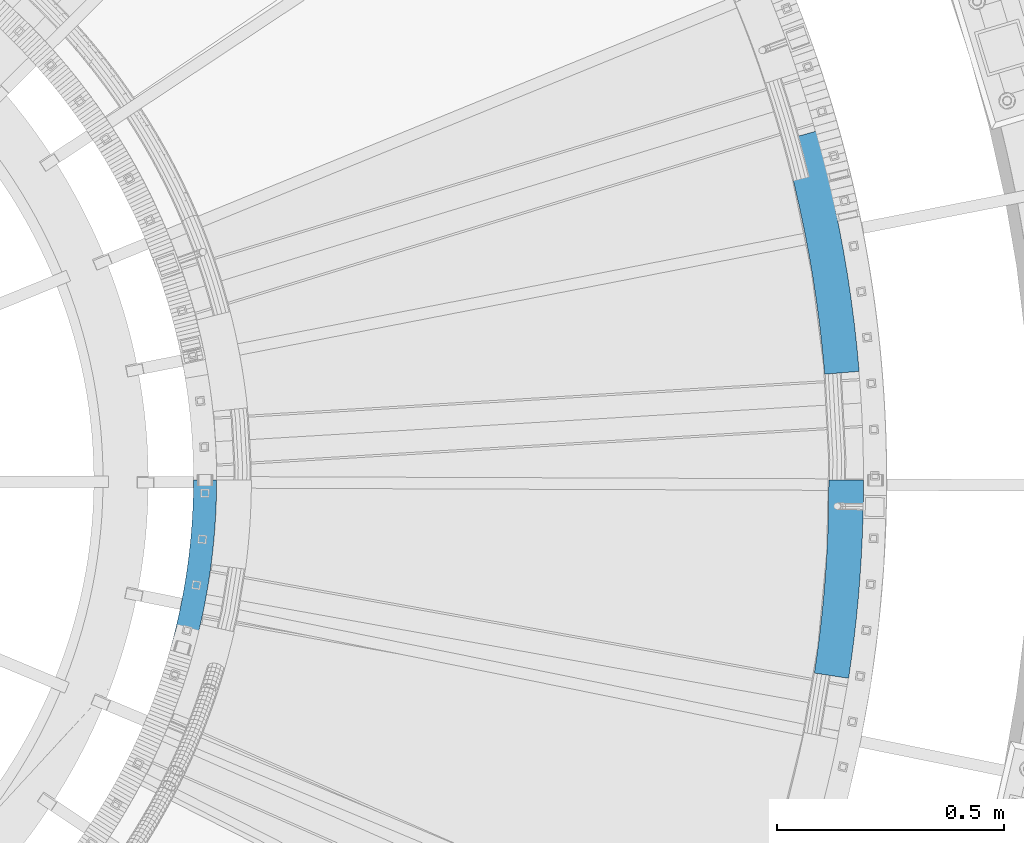
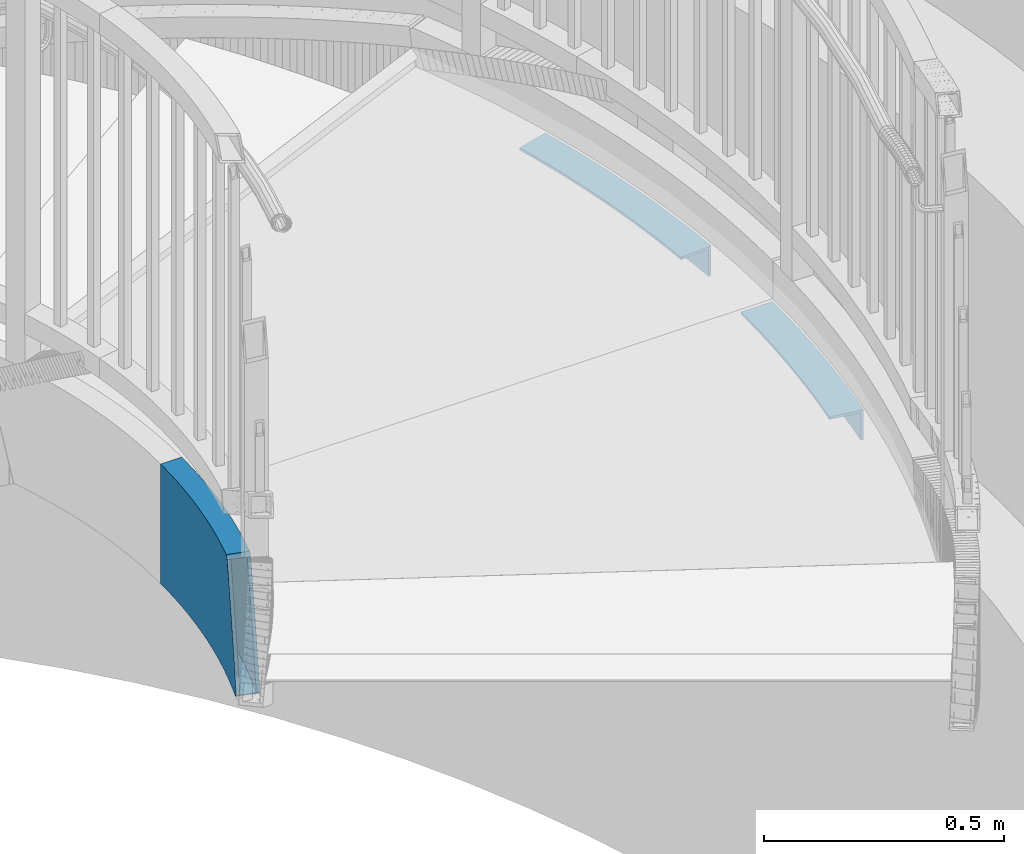
# One storey, part 503 of 975: 3 beams.
"""IFC2X3 building model written with IfcOpenShell, lengths in millimetres."""

from ifc_helpers import new_model, si_unit, frame, origin_with_axes, place, context, subcontext, project, spatial, faceted_brep, material, type_object, element, save


model = new_model("IFC2X3")

# Units and contexts
model_context = context("Model", 3, precision=1e-05, world=origin_with_axes())
body_context = subcontext(model_context, "Body", "Model", "MODEL_VIEW")
ifc_project = project(units=[si_unit("LENGTHUNIT", "METRE", prefix="MILLI"), si_unit("AREAUNIT", "SQUARE_METRE"), si_unit("VOLUMEUNIT", "CUBIC_METRE"), si_unit("MASSUNIT", "GRAM", prefix="KILO"), si_unit("TIMEUNIT", "SECOND"), si_unit("PLANEANGLEUNIT", "RADIAN"), si_unit("SOLIDANGLEUNIT", "STERADIAN"), si_unit("THERMODYNAMICTEMPERATUREUNIT", "DEGREE_CELSIUS"), si_unit("LUMINOUSINTENSITYUNIT", "LUMEN")], contexts=[model_context])

# Site, building, storey
site_placement = place(None, origin_with_axes())
site = spatial("IfcSite", under=ifc_project, at=site_placement, CompositionType="ELEMENT")
building_placement = place(site_placement, origin_with_axes())
building = spatial("IfcBuilding", under=site, at=building_placement, Name="Undefined", CompositionType="ELEMENT")
storey_placement = place(building_placement, origin_with_axes())
storey = spatial("IfcBuildingStorey", under=building, at=storey_placement, Name="Undefined", CompositionType="ELEMENT", Elevation=0.0)

# Beams
ifc_material_1 = material(Name="STEEL/A36")
beam_type_1 = type_object("IfcBeamType", Name="L3X3X1/4", PredefinedType="NOTDEFINED")
beam_1_placement = place(storey_placement, frame((37541.2001337016, 3403.49906415953, 2044.7), z_axis=(-0.997215696364152, 0.0745711400272229, 0.0), x_axis=(-0.0745711400272231, -0.997215696364152, 0.0)))
element("IfcBeam", 1, at=beam_1_placement, inside=storey, type_object=beam_type_1, material=ifc_material_1, Name="ANGLE", ObjectType="L3X3X1/4", context=body_context, shape_type="Brep", body=[
    faceted_brep([(2.94180525661432, 38.0999999999999, 37.9862578023894), (2.94180525661432, 31.75, 37.9862578023894), (45.4166700735695, 31.75, 35.0269018917315), (45.4166700735695, 38.0999999999999, 35.0269018917315), (-2.45150438051314, 31.75, -31.6552148353221), (-2.45150438051314, -38.0999999999999, -31.6552148353221), (41.1004751186192, -38.0999999999999, -34.6896166752631), (41.1004751186192, 31.75, -34.6896166752631), (-2.94180525661523, -38.0999999999999, -37.9862578023894), (-2.94180525661523, 38.0999999999999, -37.9862578023894), (40.7080937590763, 38.0999999999999, -41.027481999532), (40.7080937590763, -38.0999999999999, -41.027481999532), (87.9322040593433, 31.75, 32.7244469998332), (87.9322040593433, 38.0999999999999, 32.7244469998332), (84.6941551108348, -38.0999999999999, -37.0504592272482), (84.6941551108348, 31.75, -37.0504592272482), (84.3997870246076, 38.0999999999999, -43.3936325206159), (84.3997870246076, -38.0999999999999, -43.3936325206159), (130.47824842769, 31.75, 31.0794432820112), (130.47824842769, 38.0999999999999, 31.0794432820112), (128.319119194526, -38.0999999999999, -38.7371783846538), (128.319119194526, 31.75, -38.7371783846538), (128.122834718784, 38.0999999999999, -45.084143990709), (128.122834718784, -38.0999999999999, -45.084143990709), (173.044637102121, 31.75, 30.0922838002589), (173.044637102121, 38.0999999999999, 30.0922838002589), (171.964943492967, -38.0999999999999, -39.749371117854), (171.964943492967, 31.75, -39.749371117854), (171.866789528498, 38.0999999999999, -46.0986124740448), (171.866789528498, -38.0999999999999, -46.0986124740448), (215.621199145022, 31.75, 29.7632044293787), (215.621199145022, 38.0999999999999, 29.7632044293787), (215.621199145031, -38.0999999999999, -40.0867955705544), (215.621199145031, 31.75, -40.0867955705544), (215.621199145031, 38.0999999999999, -46.4367955705457), (215.621199145031, -38.0999999999999, -46.4367955705457), (258.197761187923, 31.75, 30.0922838005426), (258.197761187923, 38.0999999999999, 30.0922838005426), (259.277454797095, -38.0999999999999, -39.749371117563), (259.277454797095, 31.75, -39.749371117563), (259.375608761566, 38.0999999999999, -46.098612473761), (259.375608761566, -38.0999999999999, -46.098612473761), (300.764149862352, 31.75, 31.0794432825569), (300.764149862352, 38.0999999999999, 31.0794432825569), (302.923279095534, -38.0999999999999, -38.7371783840863), (302.923279095534, 31.75, -38.7371783840863), (303.119563571277, 38.0999999999999, -45.0841439901415), (303.119563571277, -38.0999999999999, -45.0841439901415), (343.310194230698, 31.75, 32.7244470006699), (343.310194230698, 38.0999999999999, 32.7244470006699), (346.548243179226, -38.0999999999999, -37.0504592264042), (346.548243179226, 31.75, -37.0504592264042), (346.842611265455, 38.0999999999999, -43.3936325197719), (346.842611265455, -38.0999999999999, -43.3936325197719), (385.825728216472, 31.75, 35.0269018928302), (385.825728216472, 38.0999999999999, 35.0269018928302), (390.141923171442, -38.0999999999999, -34.6896166741353), (390.141923171442, 31.75, -34.6896166741353), (390.534304530984, 38.0999999999999, -41.0274819984043), (390.534304530984, -38.0999999999999, -41.0274819984043), (428.300593033427, 38.0999999999999, 37.9862578037646), (434.184203546676, 38.0999999999999, -37.9862578009852), (428.300593033427, 31.75, 37.9862578037646), (433.693902670571, 31.75, -31.6552148339179), (433.693902670571, -38.0999999999999, -31.6552148339179), (434.184203546676, -38.0999999999999, -37.9862578009852)], [[[0, 1, 2, 3]], [[4, 5, 6, 7]], [[8, 9, 10, 11]], [[8, 5, 4, 1, 0, 9]], [[3, 2, 12, 13]], [[7, 6, 14, 15]], [[11, 10, 16, 17]], [[13, 12, 18, 19]], [[15, 14, 20, 21]], [[17, 16, 22, 23]], [[19, 18, 24, 25]], [[21, 20, 26, 27]], [[23, 22, 28, 29]], [[25, 24, 30, 31]], [[27, 26, 32, 33]], [[29, 28, 34, 35]], [[31, 30, 36, 37]], [[33, 32, 38, 39]], [[35, 34, 40, 41]], [[37, 36, 42, 43]], [[39, 38, 44, 45]], [[41, 40, 46, 47]], [[43, 42, 48, 49]], [[45, 44, 50, 51]], [[47, 46, 52, 53]], [[49, 48, 54, 55]], [[51, 50, 56, 57]], [[53, 52, 58, 59]], [[58, 52, 46, 40, 34, 28, 22, 16, 10, 9, 0, 3, 13, 19, 25, 31, 37, 43, 49, 55, 60, 61]], [[55, 54, 62, 60]], [[54, 48, 42, 36, 30, 24, 18, 12, 2, 1, 4, 7, 15, 21, 27, 33, 39, 45, 51, 57, 63, 62]], [[57, 56, 64, 63]], [[56, 50, 44, 38, 32, 26, 20, 14, 6, 5, 8, 11, 17, 23, 29, 35, 41, 47, 53, 59, 65, 64]], [[59, 58, 61, 65]], [[62, 63, 64, 65, 61, 60]]]),
])
beam_2_placement = place(storey_placement, frame((37438.6683845131, 4160.88867596759, 2044.7), z_axis=(-0.984369748400256, -0.176114163071617, 0.0), x_axis=(0.176114163071617, -0.984369748400256, 0.0)))
element("IfcBeam", 2, at=beam_2_placement, inside=storey, type_object=beam_type_1, material=ifc_material_1, Name="ANGLE", ObjectType="L3X3X1/4", context=body_context, shape_type="Brep", body=[
    faceted_brep([(3.61159372289876, 38.0999999999999, 37.9284377581789), (3.61159372289876, 31.75, 37.9284377581789), (55.7307038023591, 31.75, 33.4644335750272), (55.7307038023591, 38.0999999999999, 33.4644335750272), (-3.00966143574806, 31.75, -31.6070314651588), (-3.00966143574806, -38.0999999999999, -31.6070314651588), (50.4308330822914, -38.0999999999999, -36.1842122864546), (50.4308330822914, 31.75, -36.1842122864546), (-3.61159372289876, -38.0999999999999, -37.9284377581935), (-3.61159372289876, 38.0999999999999, -37.9284377581935), (49.9490266531975, 38.0999999999999, -42.5159073647665), (49.9490266531975, -38.0999999999999, -42.5159073647665), (107.925172505771, 31.75, 29.990760362125), (107.925172505771, 38.0999999999999, 29.990760362125), (103.948596803979, -38.0999999999999, -39.7459541122153), (103.948596803979, 31.75, -39.7459541122153), (103.587089921995, 38.0999999999999, -46.085655428069), (103.587089921995, -38.0999999999999, -46.085655428069), (160.176183960657, 31.75, 27.5086703631314), (160.176183960657, 38.0999999999999, 27.5086703631314), (157.524336814882, -38.0999999999999, -42.2909729504463), (157.524336814882, 31.75, -42.2909729504463), (157.28325980163, 38.0999999999999, -48.6363950698651), (157.28325980163, -38.0999999999999, -48.6363950698651), (212.464901911111, 31.75, 26.019058360398), (212.464901911111, 38.0999999999999, 26.019058360398), (211.138739300395, -38.0999999999999, -43.8183513332478), (211.138739300395, 31.75, -43.8183513332478), (211.018179063058, 38.0999999999999, -50.1672067599429), (211.018179063058, -38.0999999999999, -50.1672067599429), (264.77247650822, 31.75, 25.5224613523824), (264.77247650822, 38.0999999999999, 25.5224613523824), (264.772476508249, -38.0999999999999, -44.3275386475434), (264.772476508249, 31.75, -44.3275386475434), (264.772476508251, 38.0999999999999, -50.677538647542), (264.772476508251, -38.0999999999999, -50.677538647542), (317.080051105333, 31.75, 26.0190583600779), (317.080051105333, 38.0999999999999, 26.0190583600779), (318.406213716104, -38.0999999999999, -43.8183513335753), (318.406213716104, 31.75, -43.8183513335753), (318.526773953445, 38.0999999999999, -50.1672067602849), (318.526773953445, -38.0999999999999, -50.1672067602849), (369.368769055787, 31.75, 27.5086703624984), (369.368769055787, 38.0999999999999, 27.5086703624984), (372.020616201613, -38.0999999999999, -42.2909729511011), (372.020616201613, 31.75, -42.2909729511011), (372.261693214869, 38.0999999999999, -48.6363950705272), (372.261693214869, -38.0999999999999, -48.6363950705272), (421.619780510669, 31.75, 29.9907603611573), (421.619780510669, 38.0999999999999, 29.9907603611573), (425.596356212516, -38.0999999999999, -39.7459541132048), (425.596356212516, 31.75, -39.7459541132048), (425.957863094502, 38.0999999999999, -46.0856554290513), (425.957863094502, -38.0999999999999, -46.0856554290513), (473.814249214081, 31.75, 33.4644335737394), (473.814249214081, 38.0999999999999, 33.4644335737394), (479.114119934198, -38.0999999999999, -36.1842122877642), (479.114119934198, 31.75, -36.1842122877642), (479.595926363299, 38.0999999999999, -42.5159073660834), (479.595926363299, -38.0999999999999, -42.5159073660834), (525.933359293538, 38.0999999999999, 37.9284377565855), (533.15654673939, 38.0999999999999, -37.9284377598306), (525.933359293538, 31.75, 37.9284377565855), (532.554614452236, 31.75, -31.6070314668032), (532.554614452236, -38.0999999999999, -31.6070314668032), (533.15654673939, -38.0999999999999, -37.9284377598306)], [[[0, 1, 2, 3]], [[4, 5, 6, 7]], [[8, 9, 10, 11]], [[8, 5, 4, 1, 0, 9]], [[3, 2, 12, 13]], [[7, 6, 14, 15]], [[11, 10, 16, 17]], [[13, 12, 18, 19]], [[15, 14, 20, 21]], [[17, 16, 22, 23]], [[19, 18, 24, 25]], [[21, 20, 26, 27]], [[23, 22, 28, 29]], [[25, 24, 30, 31]], [[27, 26, 32, 33]], [[29, 28, 34, 35]], [[31, 30, 36, 37]], [[33, 32, 38, 39]], [[35, 34, 40, 41]], [[37, 36, 42, 43]], [[39, 38, 44, 45]], [[41, 40, 46, 47]], [[43, 42, 48, 49]], [[45, 44, 50, 51]], [[47, 46, 52, 53]], [[49, 48, 54, 55]], [[51, 50, 56, 57]], [[53, 52, 58, 59]], [[58, 52, 46, 40, 34, 28, 22, 16, 10, 9, 0, 3, 13, 19, 25, 31, 37, 43, 49, 55, 60, 61]], [[55, 54, 62, 60]], [[54, 48, 42, 36, 30, 24, 18, 12, 2, 1, 4, 7, 15, 21, 27, 33, 39, 45, 51, 57, 63, 62]], [[57, 56, 64, 63]], [[56, 50, 44, 38, 32, 26, 20, 14, 6, 5, 8, 11, 17, 23, 29, 35, 41, 47, 53, 59, 65, 64]], [[59, 58, 61, 65]], [[62, 63, 64, 65, 61, 60]]]),
])
ifc_material_2 = material()
beam_type_2 = type_object("IfcBeamType", Name="HSS12X2X5/16", PredefinedType="NOTDEFINED")
beam_3_placement = place(storey_placement, frame((36020.327060371, 3949.87201722461, 2031.99999923706), z_axis=(0.0, 0.0, 1.0), x_axis=(0.0627814950101885, -0.998027296161926, 0.0)))
element("IfcBeam", 3, at=beam_3_placement, inside=storey, type_object=beam_type_2, material=ifc_material_2, Name="STAIR", ObjectType="HSS12X2X5/16", context=body_context, shape_type="Brep", body=[
    faceted_brep([(925.219669040211, 28.1373271161501, 144.550246771072), (921.87849329615, 29.2881349393137, 148.083963804988), (917.781206409747, 30.6471499829131, 152.4), (900.886990780725, -17.2698966352327, 152.4), (905.610109445548, -18.8364916763239, 147.424719606928), (908.327984581839, -19.77261482842, 144.550222004626), (910.991207073406, -12.294917220308, 144.4625), (922.604244776724, 20.6431662690447, 144.4625), (994.502329506688, -6.02737329357478, -144.4625), (1000.58584877837, -8.51409721726668, -144.4625), (994.502329506688, -6.02737329357478, -121.678019766071), (979.647042510832, -0.149184540350689, -144.4625), (979.647042510832, -0.149184540350689, -66.2648583164882), (964.726581626154, 5.56155111599219, -144.4625), (964.726581626154, 5.56155111599219, -10.831615027098), (949.742834363714, 11.1041112395396, -144.4625), (949.742834363714, 11.1041112395396, 44.6146975265083), (934.697696240607, 16.4777946694157, -144.4625), (934.697696240607, 16.4777946694157, 100.067065115414), (875.64372148229, -9.08691933883529, 152.4), (875.64372148229, -9.08691933883529, -152.4), (890.65479499538, -13.8760146867862, -152.4), (890.65479499538, -13.8760146867862, 152.4), (860.578852797096, -4.46983218727837, 152.4), (860.578852797096, -4.46983218727837, -152.4), (845.462159868608, -0.0253572832007194, 152.4), (845.462159868608, -0.0253572832007194, -152.4), (830.295620405775, 4.24592390510225, 152.4), (830.295620405775, 4.24592390510225, -152.4), (815.081218638944, 8.34345256816596, 152.4), (815.081218638944, 8.34345256816596, -152.4), (799.820945060257, 12.2666926284801, 152.4), (799.820945060257, 12.2666926284801, -152.4), (784.516796163247, 16.015130810636, 152.4), (784.516796163247, 16.015130810636, -152.4), (769.170774181626, 19.5882767084186, 152.4), (769.170774181626, 19.5882767084186, -152.4), (753.784886827343, 22.9856628490452, 152.4), (753.784886827343, 22.9856628490452, -152.4), (738.361147027913, 26.2068447543061, 152.4), (738.361147027913, 26.2068447543061, -152.4), (722.901572663063, 29.2514009986553, 152.4), (722.901572663063, 29.2514009986553, -152.4), (707.408186300741, 32.1189332644135, 152.4), (707.408186300741, 32.1189332644135, -152.4), (691.883014932499, 34.8090663938347, 152.4), (691.883014932499, 34.8090663938347, -152.4), (676.328089708303, 37.3214484382333, 152.4), (676.328089708303, 37.3214484382333, -152.4), (660.745445670805, 39.6557507040052, 152.4), (660.745445670805, 39.6557507040052, -152.4), (645.137121489088, 41.8116677955986, 152.4), (645.137121489088, 41.8116677955986, -152.4), (629.505159191961, 43.7889176555327, 152.4), (629.505159191961, 43.7889176555327, -152.4), (613.851603900793, 45.5872416012498, 152.4), (613.851603900793, 45.5872416012498, -152.4), (598.178503561951, 47.2064043589708, 152.4), (598.178503561951, 47.2064043589708, -152.4), (582.487908678871, 48.646194094501, 152.4), (582.487908678871, 48.646194094501, -152.4), (566.781872043795, 49.9064224409012, 152.4), (566.781872043795, 49.9064224409012, -152.4), (551.062448469194, 50.9869245231603, 152.4), (551.062448469194, 50.9869245231603, -152.4), (550.560948877305, 51.0156369303222, 152.4), (550.560948877305, 51.0156369303222, -152.4), (890.807032915533, 39.3972428833149, -152.4), (890.807032915533, 39.3972428833149, 152.4), (906.371670752579, 34.431539758014, 152.4), (906.371670752579, 34.431539758014, -152.4), (875.18661609836, 44.184594654871, -152.4), (875.18661609836, 44.184594654871, 152.4), (859.512463911938, 48.7929687460128, -152.4), (859.512463911938, 48.7929687460128, 152.4), (843.786626997316, 53.2217622455646, -152.4), (843.786626997316, 53.2217622455646, 152.4), (828.011162757431, 57.4703957368329, -152.4), (828.011162757431, 57.4703957368329, 152.4), (812.188135087933, 61.5383133733267, -152.4), (812.188135087933, 61.5383133733267, 152.4), (796.319614107173, 65.4249829515393, -152.4), (796.319614107173, 65.4249829515393, 152.4), (780.407675885368, 69.1298959805426, -152.4), (780.407675885368, 69.1298959805426, 152.4), (764.454402172988, 72.6525677485188, -152.4), (764.454402172988, 72.6525677485188, 152.4), (748.461880128404, 75.9925373861915, -152.4), (748.461880128404, 75.9925373861915, 152.4), (732.432202044826, 79.1493679270861, -152.4), (732.432202044826, 79.1493679270861, 152.4), (716.367465076569, 82.1226463647399, -152.4), (716.367465076569, 82.1226463647399, 152.4), (700.269770964682, 84.9119837066974, -152.4), (700.269770964682, 84.9119837066974, 152.4), (684.141225761982, 87.5170150254344, -152.4), (684.141225761982, 87.5170150254344, 152.4), (667.983939557517, 89.9373995060741, -152.4), (667.983939557517, 89.9373995060741, 152.4), (651.800026200503, 92.1728204909959, -152.4), (651.800026200503, 92.1728204909959, 152.4), (635.591603023776, 94.2229855212645, -152.4), (635.591603023776, 94.2229855212645, 152.4), (619.360790566775, 96.0876263748432, -152.4), (619.360790566775, 96.0876263748432, 152.4), (603.109712298121, 97.7664991017882, -152.4), (603.109712298121, 97.7664991017882, 152.4), (586.840494337796, 99.2593840560512, -152.4), (586.840494337796, 99.2593840560512, 152.4), (570.55526517899, 100.566085924271, -152.4), (570.55526517899, 100.566085924271, 152.4), (554.256155409631, 101.686433751362, -152.4), (554.256155409631, 101.686433751362, 152.4), (553.750247250523, 101.715398562665, -152.4), (553.750247250523, 101.715398562665, 152.4), (903.915908915516, 26.8834843760123, 144.4625), (903.915908915516, 26.8834843760123, -144.4625), (919.336558319493, 21.7686620306195, -144.4625), (919.336558319493, 21.7686620306195, 144.4625), (888.437765504088, 31.8215925360928, 144.4625), (888.437765504088, 31.8215925360928, -144.4625), (872.904153082537, 36.5823404607872, 144.4625), (872.904153082537, 36.5823404607872, -144.4625), (857.317103905167, 41.1651053039459, 144.4625), (857.317103905167, 41.1651053039459, -144.4625), (841.678657217388, 45.5692875048626, 144.4625), (841.678657217388, 45.5692875048626, -144.4625), (825.990858988917, 49.7943108667241, 144.4625), (825.990858988917, 49.7943108667241, -144.4625), (810.255761646109, 53.8396226319383, 144.4625), (810.255761646109, 53.8396226319383, -144.4625), (794.475423803435, 57.7046935545222, 144.4625), (794.475423803435, 57.7046935545222, -144.4625), (778.651909994159, 61.3890179692753, 144.4625), (778.651909994159, 61.3890179692753, -144.4625), (762.787290400231, 64.8921138579753, 144.4625), (762.787290400231, 64.8921138579753, -144.4625), (746.883640581453, 68.2135229124615, 144.4625), (746.883640581453, 68.2135229124615, -144.4625), (730.943041203926, 71.3528105945152, 144.4625), (730.943041203926, 71.3528105945152, -144.4625), (714.967577767845, 74.3095661928091, 144.4625), (714.967577767845, 74.3095661928091, -144.4625), (698.959340334653, 77.0834028765603, 144.4625), (698.959340334653, 77.0834028765603, -144.4625), (682.920423253595, 79.6739577461849, 144.4625), (682.920423253595, 79.6739577461849, -144.4625), (666.852924887718, 82.0808918807525, 144.4625), (666.852924887718, 82.0808918807525, -144.4625), (650.758947339345, 84.3038903823472, 144.4625), (650.758947339345, 84.3038903823472, -144.4625), (634.640596175055, 86.3426624172353, 144.4625), (634.640596175055, 86.3426624172353, -144.4625), (618.499980150215, 88.1969412539693, 144.4625), (618.499980150215, 88.1969412539693, -144.4625), (602.339210933094, 89.8664842982253, 144.4625), (602.339210933094, 89.8664842982253, -144.4625), (586.160402828588, 91.3510731245551, 144.4625), (586.160402828588, 91.3510731245551, -144.4625), (569.965672501616, 92.6505135049956, 144.4625), (569.965672501616, 92.6505135049956, -144.4625), (553.757138700188, 93.7646354344542, 144.4625), (553.757138700188, 93.7646354344542, -144.4625), (553.251919379708, 93.793560807615, 144.4625), (553.251919379708, 93.793560807615, -144.4625), (551.05927674812, 58.9374746853719, -144.4625), (551.05927674812, 58.9374746853719, 144.4625), (551.561465178637, 58.9087228400676, 144.4625), (551.561465178637, 58.9087228400676, -144.4625), (567.371464721169, 57.8219948601763, 144.4625), (567.371464721169, 57.8219948601763, -144.4625), (583.168000188078, 56.5545050259898, 144.4625), (583.168000188078, 56.5545050259898, -144.4625), (598.949004926978, 55.106419162541, 144.4625), (598.949004926978, 55.106419162541, -144.4625), (614.712414317353, 53.4779267221238, 144.4625), (614.712414317353, 53.4779267221238, -144.4625), (630.456166040683, 51.6692407595547, 144.4625), (630.456166040683, 51.6692407595547, -144.4625), (646.178200350247, 49.6805979042547, 144.4625), (646.178200350247, 49.6805979042547, -144.4625), (661.876460340603, 47.5122583293269, 144.4625), (661.876460340603, 47.5122583293269, -144.4625), (677.548892216691, 45.1645057174828, 144.4625), (677.548892216691, 45.1645057174828, -144.4625), (693.193445562527, 42.6376472239644, 144.4625), (693.193445562527, 42.6376472239644, -144.4625), (708.808073609464, 39.932013436337, 144.4625), (708.808073609464, 39.932013436337, -144.4625), (724.390733503963, 37.0479583312263, 144.4625), (724.390733503963, 37.0479583312263, -144.4625), (739.939386574864, 33.9858592280434, 144.4625), (739.939386574864, 33.9858592280434, -144.4625), (755.451998600101, 30.7461167395959, 144.4625), (755.451998600101, 30.7461167395959, -144.4625), (770.926540072836, 27.3291547196859, 144.4625), (770.926540072836, 27.3291547196859, -144.4625), (786.360986466985, 23.7354202076458, 144.4625), (786.360986466985, 23.7354202076458, -144.4625), (801.753318502082, 19.9653833698685, 144.4625), (801.753318502082, 19.9653833698685, -144.4625), (817.101522407457, 16.0195374382674, 144.4625), (817.101522407457, 16.0195374382674, -144.4625), (832.403590185704, 11.8983986457897, 144.4625), (832.403590185704, 11.8983986457897, -144.4625), (847.657519875378, 7.60250615886616, 144.4625), (847.657519875378, 7.60250615886616, -144.4625), (862.861315812918, 3.13242200679815, 144.4625), (862.861315812918, 3.13242200679815, -144.4625), (878.012988893734, -1.51126899162045, 144.4625), (878.012988893734, -1.51126899162045, -144.4625), (893.110556832442, -6.3279593047846, 144.4625), (893.110556832442, -6.3279593047846, -144.4625), (908.152044422204, -11.3170187676369, 144.4625), (908.152044422204, -11.3170187676369, -144.4625), (937.810693146302, -21.7193503538074, -144.4625), (923.135483793148, -16.477794664148, -144.4625), (923.135483793148, -16.477794664148, 99.8804840269886), (937.810693146302, -21.7193503538074, 45.7915752488457), (952.426021112839, -27.1256304092021, -144.4625), (952.426021112839, -27.1256304092021, -8.29142737476786), (966.979618782502, -32.695950909525, -144.4625), (966.979618782502, -32.695950909525, -62.3616820802918), (981.469645054216, -38.4296071820791, -144.4625), (981.469645054216, -38.4296071820791, -116.412348716835), (988.959113067214, -41.49103239533, -144.4625), (920.507708236906, -23.967701330861, -152.4), (935.098842869618, -29.1792279886649, -152.4), (935.098842869618, -29.1792279886649, 46.0590474584678), (920.507708236906, -23.967701330861, 99.838079234165), (949.630439177995, -34.5545353012858, -152.4), (949.630439177995, -34.5545353012858, -7.71411199923864), (964.100658844246, -40.0929432661578, -152.4), (964.100658844246, -40.0929432661578, -61.4745965720651), (978.507671315018, -45.7937512476419, -152.4), (978.507671315018, -45.7937512476419, -115.215605296555), (978.931646566765, -45.9670570850212, -152.4), (986.310231609521, -48.9831573272313, -144.43837469446), (967.522163560998, 12.9904560080831, -152.4), (952.454684640399, 18.5639888743972, -152.4), (952.454684640399, 18.5639888743972, 44.3472253168861), (967.522163560998, 12.9904560080831, -11.4089304026272), (982.526002449089, 7.24780781628215, -152.4), (982.526002449089, 7.24780781628215, -67.1519438247142), (997.464303245886, 1.33677077198809, -122.874763186352), (1003.22185084837, -1.01670765480958, -144.438388398365), (997.464303245886, 1.33677077198809, -150.650885296368), (995.836724535011, 1.98079837481782, -152.4), (905.610109445548, -18.8364916763239, -152.4), (921.87849329615, 29.2881349393137, -152.4), (937.325471796849, 23.9677013361288, -152.4), (937.325471796849, 23.9677013361288, 100.109469908238)], [[[0, 1, 2, 3, 4, 5, 6, 7]], [[8, 9, 10]], [[11, 8, 10, 12]], [[13, 11, 12, 14]], [[15, 13, 14, 16]], [[17, 15, 16, 18]], [[19, 20, 21, 22]], [[23, 24, 20, 19]], [[25, 26, 24, 23]], [[27, 28, 26, 25]], [[29, 30, 28, 27]], [[31, 32, 30, 29]], [[33, 34, 32, 31]], [[35, 36, 34, 33]], [[37, 38, 36, 35]], [[39, 40, 38, 37]], [[41, 42, 40, 39]], [[43, 44, 42, 41]], [[45, 46, 44, 43]], [[47, 48, 46, 45]], [[49, 50, 48, 47]], [[51, 52, 50, 49]], [[53, 54, 52, 51]], [[55, 56, 54, 53]], [[57, 58, 56, 55]], [[59, 60, 58, 57]], [[61, 62, 60, 59]], [[63, 64, 62, 61]], [[64, 63, 65, 66]], [[67, 68, 69, 70]], [[71, 72, 68, 67]], [[73, 74, 72, 71]], [[75, 76, 74, 73]], [[77, 78, 76, 75]], [[79, 80, 78, 77]], [[81, 82, 80, 79]], [[83, 84, 82, 81]], [[85, 86, 84, 83]], [[87, 88, 86, 85]], [[89, 90, 88, 87]], [[91, 92, 90, 89]], [[93, 94, 92, 91]], [[95, 96, 94, 93]], [[97, 98, 96, 95]], [[99, 100, 98, 97]], [[101, 102, 100, 99]], [[103, 104, 102, 101]], [[105, 106, 104, 103]], [[107, 108, 106, 105]], [[109, 110, 108, 107]], [[111, 112, 110, 109]], [[112, 111, 113, 114]], [[115, 116, 117, 118]], [[119, 120, 116, 115]], [[121, 122, 120, 119]], [[123, 124, 122, 121]], [[125, 126, 124, 123]], [[127, 128, 126, 125]], [[129, 130, 128, 127]], [[131, 132, 130, 129]], [[133, 134, 132, 131]], [[135, 136, 134, 133]], [[137, 138, 136, 135]], [[139, 140, 138, 137]], [[141, 142, 140, 139]], [[143, 144, 142, 141]], [[145, 146, 144, 143]], [[147, 148, 146, 145]], [[149, 150, 148, 147]], [[151, 152, 150, 149]], [[153, 154, 152, 151]], [[155, 156, 154, 153]], [[157, 158, 156, 155]], [[159, 160, 158, 157]], [[161, 162, 160, 159]], [[162, 161, 163, 164]], [[66, 65, 114, 113], [165, 164, 163, 166]], [[167, 168, 165, 166]], [[168, 167, 169, 170]], [[170, 169, 171, 172]], [[172, 171, 173, 174]], [[174, 173, 175, 176]], [[176, 175, 177, 178]], [[178, 177, 179, 180]], [[180, 179, 181, 182]], [[182, 181, 183, 184]], [[184, 183, 185, 186]], [[186, 185, 187, 188]], [[188, 187, 189, 190]], [[190, 189, 191, 192]], [[192, 191, 193, 194]], [[194, 193, 195, 196]], [[196, 195, 197, 198]], [[198, 197, 199, 200]], [[200, 199, 201, 202]], [[202, 201, 203, 204]], [[204, 203, 205, 206]], [[206, 205, 207, 208]], [[208, 207, 209, 210]], [[210, 209, 211, 212]], [[212, 211, 213, 214]], [[215, 216, 217, 218]], [[219, 215, 218, 220]], [[221, 219, 220, 222]], [[223, 221, 222, 224]], [[223, 224, 225]], [[8, 11, 13, 15, 17, 117, 116, 120, 122, 124, 126, 128, 130, 132, 134, 136, 138, 140, 142, 144, 146, 148, 150, 152, 154, 156, 158, 160, 162, 164, 165, 168, 170, 172, 174, 176, 178, 180, 182, 184, 186, 188, 190, 192, 194, 196, 198, 200, 202, 204, 206, 208, 210, 212, 214, 216, 215, 219, 221, 223, 225, 9]], [[226, 227, 228, 229]], [[227, 230, 231, 228]], [[230, 232, 233, 231]], [[232, 234, 235, 233]], [[235, 234, 236, 237]], [[238, 239, 240, 241]], [[242, 238, 241, 243]], [[244, 245, 246]], [[242, 243, 244, 246, 247]], [[245, 9, 225, 237, 236, 247, 246]], [[234, 232, 230, 227, 226, 248, 21, 20, 24, 26, 28, 30, 32, 34, 36, 38, 40, 42, 44, 46, 48, 50, 52, 54, 56, 58, 60, 62, 64, 66, 113, 111, 109, 107, 105, 103, 101, 99, 97, 95, 93, 91, 89, 87, 85, 83, 81, 79, 77, 75, 73, 71, 67, 70, 249, 250, 239, 238, 242, 247, 236]], [[239, 250, 251, 240]], [[18, 16, 14, 12, 10, 9, 245, 244, 243, 241, 240, 251, 0, 7]], [[118, 117, 17, 18, 7]], [[213, 211, 209, 207, 205, 203, 201, 199, 197, 195, 193, 191, 189, 187, 185, 183, 181, 179, 177, 175, 173, 171, 169, 167, 166, 163, 161, 159, 157, 155, 153, 151, 149, 147, 145, 143, 141, 139, 137, 135, 133, 131, 129, 127, 125, 123, 121, 119, 115, 118, 7, 6]], [[216, 214, 213, 6, 217]], [[229, 228, 231, 233, 235, 237, 225, 224, 222, 220, 218, 217, 6, 5]], [[248, 226, 229, 5, 4]], [[22, 21, 248, 4, 3]], [[69, 68, 72, 74, 76, 78, 80, 82, 84, 86, 88, 90, 92, 94, 96, 98, 100, 102, 104, 106, 108, 110, 112, 114, 65, 63, 61, 59, 57, 55, 53, 51, 49, 47, 45, 43, 41, 39, 37, 35, 33, 31, 29, 27, 25, 23, 19, 22, 3, 2]], [[249, 70, 69, 2, 1]], [[251, 250, 249, 1, 0]]]),
])

save(model, "model.ifc")
